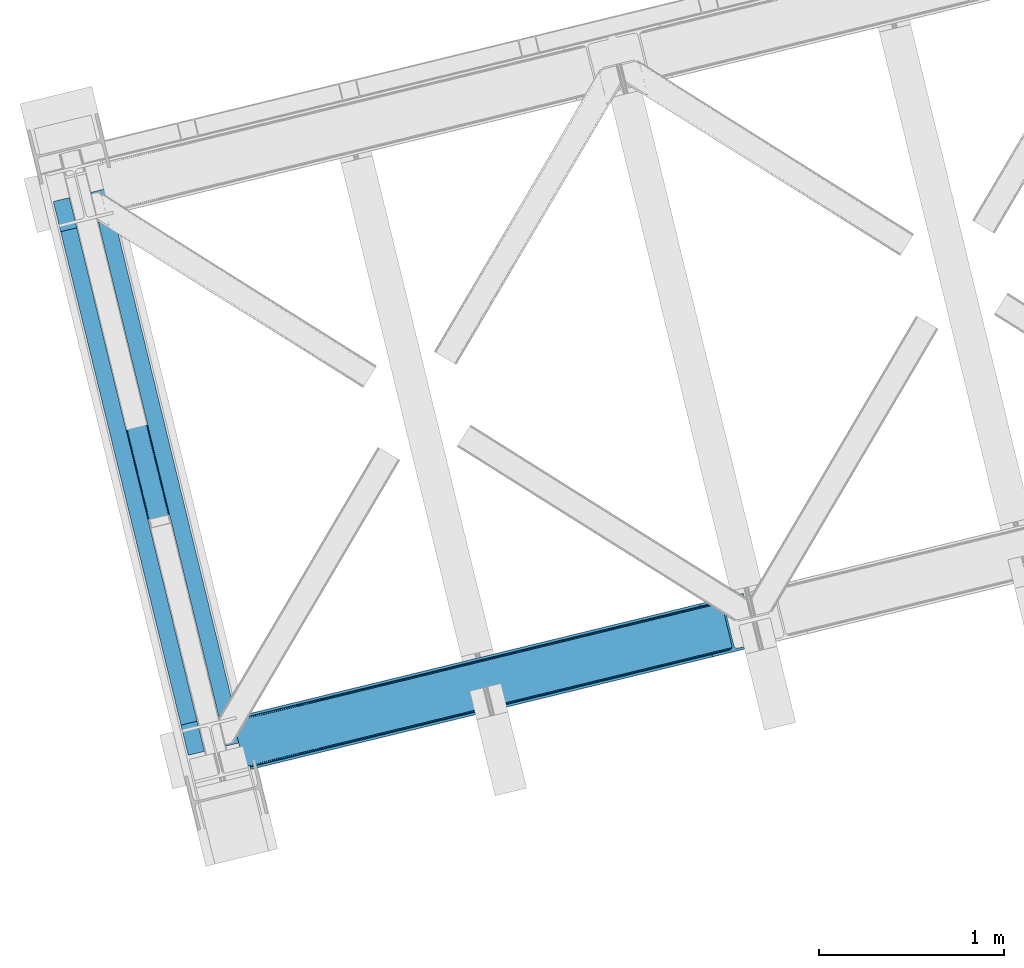
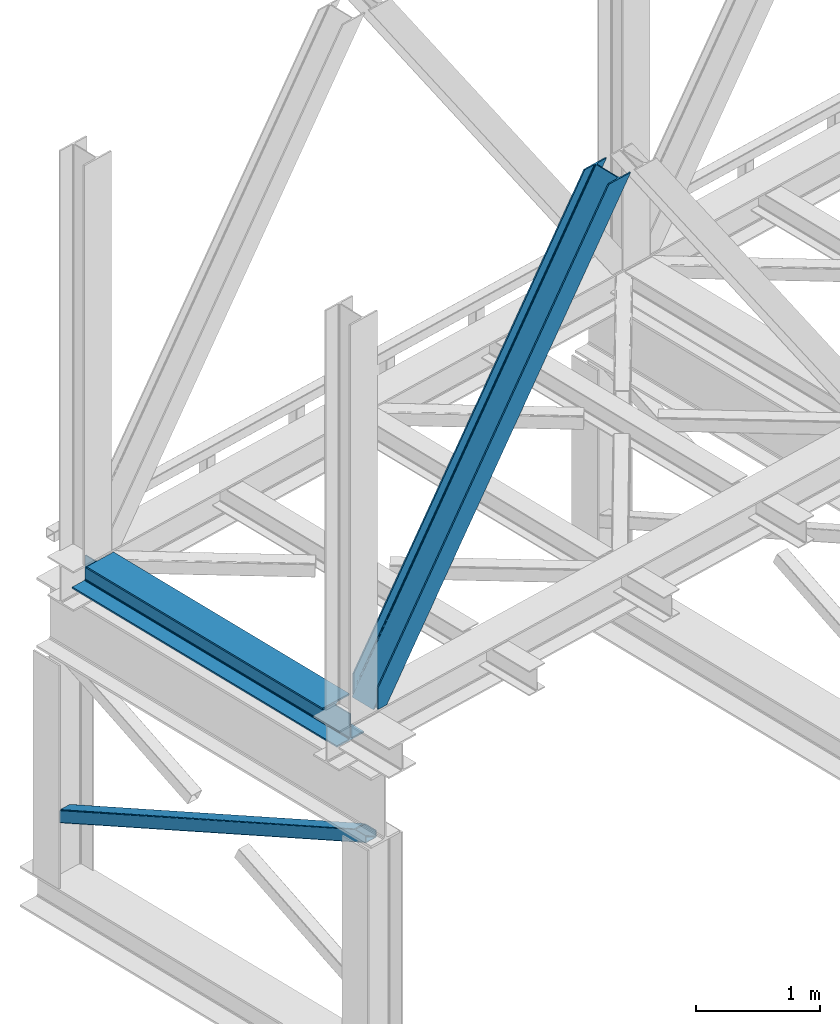
# One storey, part 24 of 92: 2 members, 1 beam.
"""IFC4 building model written with IfcOpenShell, lengths in millimetres."""

from ifc_helpers import new_model, entity, si_unit, converted_unit, derived_unit, direction, frame, origin, place, context, subcontext, project, spatial, triangles, polygons, material, type_object, element, save


model = new_model("IFC4")

# Units and contexts
model_context = context("Model", 3, precision=0.01, world=origin(), true_north=direction((6.12303176911189e-17, 1.0)))
plan_context = context("Plan", 3, precision=0.01, world=origin(), true_north=direction((6.12303176911189e-17, 1.0)))
body_context = subcontext(model_context, "Body", "Model", "MODEL_VIEW")
ifc_project = project(units=[si_unit("LENGTHUNIT", "METRE", prefix="MILLI"), si_unit("AREAUNIT", "SQUARE_METRE"), si_unit("VOLUMEUNIT", "CUBIC_METRE"), converted_unit("PLANEANGLEUNIT", "DEGREE", entity("IfcRatioMeasure", 0.0174532925199433), si_unit("PLANEANGLEUNIT", "RADIAN"), dimensions=[0, 0, 0, 0, 0, 0, 0]), si_unit("MASSUNIT", "GRAM", prefix="KILO"), derived_unit("MASSDENSITYUNIT", [(si_unit("MASSUNIT", "GRAM", prefix="KILO"), 1), (si_unit("LENGTHUNIT", "METRE"), -3)]), derived_unit("MOMENTOFINERTIAUNIT", [(si_unit("LENGTHUNIT", "METRE"), 4)]), si_unit("TIMEUNIT", "SECOND"), si_unit("FREQUENCYUNIT", "HERTZ"), si_unit("THERMODYNAMICTEMPERATUREUNIT", "DEGREE_CELSIUS"), derived_unit("THERMALTRANSMITTANCEUNIT", [(si_unit("MASSUNIT", "GRAM", prefix="KILO"), 1), (si_unit("THERMODYNAMICTEMPERATUREUNIT", "KELVIN"), -1), (si_unit("TIMEUNIT", "SECOND"), -3)]), derived_unit("VOLUMETRICFLOWRATEUNIT", [(si_unit("LENGTHUNIT", "METRE"), 3), (si_unit("TIMEUNIT", "SECOND"), -1)]), derived_unit("MASSFLOWRATEUNIT", [(si_unit("MASSUNIT", "GRAM", prefix="KILO"), 1), (si_unit("TIMEUNIT", "SECOND"), -1)]), derived_unit("ROTATIONALFREQUENCYUNIT", [(si_unit("TIMEUNIT", "SECOND"), -1)]), si_unit("ELECTRICCURRENTUNIT", "AMPERE"), si_unit("ELECTRICVOLTAGEUNIT", "VOLT"), si_unit("POWERUNIT", "WATT"), si_unit("FORCEUNIT", "NEWTON", prefix="KILO"), si_unit("ILLUMINANCEUNIT", "LUX"), si_unit("LUMINOUSFLUXUNIT", "LUMEN"), si_unit("LUMINOUSINTENSITYUNIT", "CANDELA"), derived_unit("USERDEFINED", [(si_unit("MASSUNIT", "GRAM", prefix="KILO"), -1), (si_unit("LENGTHUNIT", "METRE"), -2), (si_unit("TIMEUNIT", "SECOND"), 3), (si_unit("LUMINOUSFLUXUNIT", "LUMEN"), 1)]), derived_unit("LINEARVELOCITYUNIT", [(si_unit("LENGTHUNIT", "METRE"), 1), (si_unit("TIMEUNIT", "SECOND"), -1)]), si_unit("PRESSUREUNIT", "PASCAL"), derived_unit("USERDEFINED", [(si_unit("LENGTHUNIT", "METRE"), -2), (si_unit("MASSUNIT", "GRAM", prefix="KILO"), 1), (si_unit("TIMEUNIT", "SECOND"), -2)]), derived_unit("LINEARFORCEUNIT", [(si_unit("MASSUNIT", "GRAM", prefix="KILO"), 1), (si_unit("LENGTHUNIT", "METRE"), 1), (si_unit("TIMEUNIT", "SECOND"), -2), (si_unit("LENGTHUNIT", "METRE"), -1)]), derived_unit("PLANARFORCEUNIT", [(si_unit("MASSUNIT", "GRAM", prefix="KILO"), 1), (si_unit("LENGTHUNIT", "METRE"), 1), (si_unit("TIMEUNIT", "SECOND"), -2), (si_unit("LENGTHUNIT", "METRE"), -2)])], contexts=[model_context, plan_context])

# Site, building, storey
site_placement = place(None, origin())
site = spatial("IfcSite", under=ifc_project, at=site_placement, CompositionType="ELEMENT")
building_placement = place(site_placement, origin())
building = spatial("IfcBuilding", under=site, at=building_placement, CompositionType="ELEMENT")
storey_placement = place(building_placement, frame((0.0, 0.0, 15900.0)))
storey = spatial("IfcBuildingStorey", under=building, at=storey_placement, Name="05", CompositionType="ELEMENT", Elevation=15900.0)

# Beam
ifc_material = material(Name="Metal painted (White)")
beam_type = type_object("IfcBeamType", PredefinedType="BEAM")
beam_placement = place(storey_placement, frame((-61153.94, 2879.79, 3385.0)))
element("IfcBeam", 1, at=beam_placement, inside=storey, type_object=beam_type, material=ifc_material, ObjectType="Steel Beam", PredefinedType="BEAM", context=body_context, shape_type="Tessellation", body=[
    polygons([(1022.42935345713, 71.0478278971005, 15.4999999999986), (1022.42935345711, 71.0478278971005, 0.0), (291.465617442429, 3069.74325535076, 0.0), (291.465617442446, 3069.74325535076, 15.4999999999986), (899.042242073153, 40.970914087328, 15.4999999999986), (168.078506058474, 3039.66634154099, 15.4999999999986), (892.34989829919, 39.3395844888232, 16.8701684147963), (161.386162284511, 3038.03501194248, 16.8701684147963), (886.676403198575, 37.9566100336508, 20.7720779386413), (155.712667183895, 3036.65203748731, 20.7720779386413), (882.88549497, 37.0325360459173, 26.6116982174294), (151.92175895532, 3035.72796349958, 26.6116982174294), (881.554305026603, 36.7080444135018, 33.500000000001), (150.590569011932, 3035.40347186716, 33.500000000001), (140.875048430514, 3033.03521093726, 33.500000000001), (140.875048430514, 3033.03521093726, 259.000000000002), (150.590569011924, 3035.40347186716, 259.000000000002), (-8.66293703438714e-12, 2998.69542745366, 0.0), (-8.66293703438714e-12, 2998.69542745366, 15.4999999999986), (123.387111383964, 3028.77234126343, 15.4999999999986), (130.079455157918, 3030.40367086194, 16.8701684147963), (135.752950258542, 3031.78664531711, 20.7720779386413), (139.543858487117, 3032.71071930484, 26.6116982174294), (881.554305026594, 36.7080444135013, 259.000000000002), (871.838784445184, 34.3397834835981, 259.000000000002), (871.838784445184, 34.3397834835981, 33.500000000001), (870.507594501779, 34.0152918511832, 26.6116982174294), (866.716686273221, 33.0912178634486, 20.7720779386413), (861.043191172597, 31.7082434082767, 16.8701684147963), (854.350847398634, 30.0769138097725, 15.4999999999986), (730.963736014671, -5.41433564649196e-13, 15.4999999999986), (730.963736014671, -5.41433564649196e-13, 0.0), (841.854534586231, 199.571930111228, 259.069791776412), (190.199733064555, 2872.911390143, 259.000000000002), (190.423126166404, 2871.99494573803, 259.61730333112), (190.43551501003, 2871.94412150426, 266.500003008253), (841.709355772731, 200.167408132522, 266.500002998871), (841.709705893475, 200.165971827788, 260.000004007589), (832.229597305436, 196.831858094284, 259.006343172366), (832.006227290712, 197.74830961273, 259.61730333112), (831.993838447078, 197.799133846503, 266.500003008253), (180.719997684385, 2869.57584721824, 266.500002998871), (180.719647563625, 2869.57728352297, 260.000004007589), (180.574841905289, 2870.17133233676, 259.07612046749), (180.484212483136, 2870.5431292131, 259.000000000002), (843.040843642659, 200.490677577208, 273.388305639783), (846.831120231346, 201.417342749121, 279.227924098781), (852.504191178885, 202.802057212798, 283.129832400619), (859.196382860018, 204.434010743611, 284.500000377228), (982.583411547862, 234.511263798722, 284.500000138971), (982.58174174121, 234.518113867454, 299.999995328161), (691.11631964394, 163.469484603412, 299.999995890962), (691.1179894506, 163.46263453468, 284.500000701776), (814.505018138427, 193.539887589791, 284.500000463519), (821.197505034574, 195.17063005637, 283.129832461069), (826.871416683335, 196.551895700895, 279.227924137322), (830.662951470335, 197.473399350192, 273.388305663684), (179.38850981445, 2869.25257777355, 273.388305639783), (175.598233225754, 2868.32591260164, 279.227924098781), (169.925162278215, 2866.94119813796, 283.129832400619), (163.232970597099, 2865.30924460715, 284.500000377228), (39.8459419092461, 2835.23199155204, 284.500000138971), (39.8476117159065, 2835.2251414833, 299.999995328161), (331.313033813168, 2906.27377074735, 299.999995890962), (331.311364006516, 2906.28062081608, 284.500000701776), (207.924335318672, 2876.20336776097, 284.500000463519), (201.231848422525, 2874.57262529439, 283.129832461069), (195.557936773773, 2873.19135964986, 279.227924137322), (191.766401986782, 2872.26985600057, 273.388305663684)], [[[1, 2, 3, 4]], [[5, 1, 4, 6]], [[7, 5, 6, 8]], [[9, 7, 8, 10]], [[11, 9, 10, 12]], [[13, 11, 12, 14]], [[15, 16, 17, 14, 12, 10, 8, 6, 4, 3, 18, 19, 20, 21, 22, 23]], [[13, 24, 25, 26, 27, 28, 29, 30, 31, 32, 2, 1, 5, 7, 9, 11]], [[2, 32, 18, 3]], [[32, 31, 19, 18]], [[31, 30, 20, 19]], [[27, 26, 15, 23]], [[28, 27, 23, 22]], [[29, 28, 22, 21]], [[30, 29, 21, 20]], [[33, 24, 13, 14, 17, 34, 35, 36, 37, 38]], [[25, 39, 40, 41, 42, 43, 44, 16, 15, 26]], [[39, 25, 24, 33]], [[45, 34, 17, 16]], [[41, 40, 38, 37, 46, 47, 48, 49, 50, 51, 52, 53, 54, 55, 56, 57]], [[42, 58, 59, 60, 61, 62, 63, 64, 65, 66, 67, 68, 69, 36, 35, 43]], [[46, 37, 36, 69]], [[47, 46, 69, 68]], [[48, 47, 68, 67]], [[49, 48, 67, 66]], [[50, 49, 66, 65]], [[51, 50, 65, 64]], [[52, 51, 64, 63]], [[53, 52, 63, 62]], [[54, 53, 62, 61]], [[55, 54, 61, 60]], [[56, 55, 60, 59]], [[57, 56, 59, 58]], [[41, 57, 58, 42]]], closed=False),
])

# Members
member_type_1 = type_object("IfcMemberType", PredefinedType="BRACE")
member_1_placement = place(storey_placement, frame((-60179.56, 2803.34, 3685.0)))
element("IfcMember", 2, at=member_1_placement, inside=storey, type_object=member_type_1, ObjectType="Steel Vertical Brace", PredefinedType="BRACE", context=body_context, shape_type="Tessellation", body=[
    triangles([(58.5731689453096, 23.1982933044433, 0.0), (60.4660766601592, 15.4260932922361, 0.0), (59.1080200195283, 16.2394157409667, 0.781347656247817), (58.9684936523408, 15.0609992980958, 1.0697021484375), (78.1673217773423, 19.740655517578, 8.06229858398365), (78.1673217773423, 19.740655517578, 29.5563354492188), (72.7350952148408, 18.4163177490232, 0.0), (500.42061767578, 117.802693176269, 660.427130126951), (82.4554321289033, 19.9240745544435, 36.4024291992173), (86.4877441406279, 18.4526527404782, 44.3670593261704), (502.150744628903, 124.235730743408, 658.201684570311), (88.0643920898438, 17.2873168945312, 48.5435485839844), (2700.97932128907, 660.223363494873, 3921.00020141601), (2700.97001953125, 667.310721588135, 3921.00020141601), (2273.78214111328, 563.179286956787, 3287.10633544922), (2274.3169921875, 556.220118713379, 3287.88535766601), (2697.74696044922, 653.425231933594, 3921.00020141601), (2272.58686523438, 549.787371826172, 3290.11080322265), (2691.77058105469, 647.951147460938, 3921.00020141601), (2268.84755859375, 544.860056304932, 3293.43850708008), (2683.94780273438, 644.634780120849, 3921.00020141601), (2263.67578125, 542.188417053223, 3297.36384887695), (491.5048828125, 110.204029083252, 667.68017578125), (496.681311035158, 112.875377655029, 663.754833984374), (91.1758300781221, 12.6192878723145, 73.6396911621086), (90.6456298828125, 13.9003143310547, 61.2474243164033), (89.48291015625, 15.426383972168, 55.5245178222649), (501.611242675783, 131.194608306885, 657.42033691406), (945.193469238278, 232.231755065918, 1315.62202148437), (944.653967285158, 239.190632629394, 1314.84299926758), (1388.23619384765, 340.227779388428, 1973.04468383789), (1387.69669189453, 347.186947631836, 1972.26333618164), (1831.27426757813, 448.224094390869, 2630.46502075195), (1830.73941650391, 455.182971954346, 2629.6836730957), (943.458691406253, 225.799008178711, 1317.84746704101), (1386.50141601563, 333.795032501221, 1975.26780395508), (1829.544140625, 441.791347503662, 2632.68814086914), (939.724035644533, 220.871692657471, 1321.17517089844), (1382.76676025391, 328.86771697998, 1978.5955078125), (1825.80483398437, 436.864031982422, 2636.01817016601), (934.547607421875, 218.200053405762, 1325.10051269531), (1377.59033203125, 326.196077728272, 1982.52317504883), (1820.63305664063, 434.192392730713, 2639.94351196289), (91.1758300781221, 12.6192878723145, 210.054620361327), (2592.01853027344, 622.225392150879, 3921.00020141601), (1332.51866455078, 573.558595275879, 1972.26333618164), (2645.7873413086, 893.682369232178, 3921.00020141601), (2218.59946289063, 789.55093460083, 3287.10633544922), (1775.55673828125, 681.554619598388, 2629.6836730957), (889.475939941403, 465.562280273437, 1314.84299926758), (446.433215332028, 357.566255950928, 657.42033691406), (3.39049072265334, 249.569940948486, 0.0), (86.4877441406279, 18.4526527404782, 15.6757873535134), (82.4554321289033, 19.9240745544435, 13.352673339843), (84.3529907226548, 19.4549171447752, 14.892114257811), (88.0643920898438, 17.2873168945312, 15.1293090820291), (91.4595336914063, 11.6585906982423, 0.0), (90.6456298828125, 13.9003143310547, 7.3414123535149), (89.6456909179688, 15.5502136230466, 12.4201721191384), (91.4595336914063, 11.6585906982423, 210.119732666015), (91.1153686523467, 12.7907890319825, 0.0), (2595.09741210938, 609.595349121093, 3921.00020141601), (94.3012207031279, 0.0, 210.119732666015), (94.3012207031279, 0.0, 0.0), (189.179150390628, 23.1273674011231, 0.0), (2831.57600097657, 667.239795684814, 3921.00020141601), (94.1663452148423, 13.3483131408689, 0.0), (186.100268554685, 35.7577011108397, 0.0), (2828.49711914063, 679.8698387146, 3921.00020141601), (1411.90916748047, 334.561846160889, 1955.37134399414), (2305.60810546875, 552.410758209228, 3281.5159790039), (1858.76096191406, 443.486302185058, 2618.4424987793), (2736.56319580078, 657.460741424561, 3921.00020141601), (965.057373046875, 225.637390136719, 1292.29786376953), (518.210229492186, 116.712934112549, 629.226708984374), (512.387329101563, 116.703632354736, 633.152050781249), (72.1351318359375, 19.4709045410154, 0.0), (502.299572753909, 124.272356414795, 638.705200195313), (506.796972656251, 119.358121490478, 636.479754638669), (499.574157714844, 130.698126983642, 639.484222412109), (2728.0939453125, 656.806420898437, 3921.00020141601), (2299.78520507813, 552.401747131348, 3285.44132080078), (2720.26651611328, 658.914141082764, 3921.00020141601), (2294.19949951172, 555.05623626709, 3288.7690246582), (2714.27153320313, 663.462991333008, 3921.00020141601), (2289.70209960938, 559.970471191406, 3290.99447021484), (2711.02056884766, 669.760572052002, 3921.00020141601), (2286.97668457031, 566.395951080322, 3291.77349243164), (68.6237182617188, 25.6484344482419, 0.0), (959.234472656251, 225.628088378906, 1296.22320556641), (1406.08626708984, 334.552544403076, 1959.29668579101), (1852.93806152344, 443.477000427246, 2622.37016601562), (953.648767089842, 228.282577514648, 1299.55323486328), (1400.50056152344, 337.207033538818, 1962.62438964844), (1847.35235595703, 446.131489562988, 2625.69786987305), (949.1513671875, 233.196812438965, 1301.77635498047), (1396.00316162109, 342.121268463135, 1964.84983520508), (1842.85030517578, 451.046015167236, 2627.92098999023), (946.425952148435, 239.622583007812, 1302.55770263672), (1393.27774658203, 348.547039031982, 1965.62885742187), (1840.12954101562, 457.471495056152, 2628.70233764648), (1784.94686279297, 683.843142700195, 2628.70233764648), (1338.09506835938, 574.918686676025, 1965.62885742187), (2655.837890625, 896.132219696045, 3921.00020141601), (2231.79865722657, 792.767598724365, 3291.77349243164), (891.247924804688, 465.994230651856, 1302.55770263672), (444.396130371097, 357.069774627686, 639.484222412109), (13.4410400390625, 252.020082092285, 0.0), (1.49758300781104, 257.342431640625, 0.0), (13.7154418945283, 259.120811462402, 0.0), (13.7619506835908, 260.332946777344, 0.0), (0.665075683595205, 255.995711517334, 0.781347656247817), (0.0, 256.977628326416, 1.0697021484375), (19.1988281250015, 261.656993865967, 8.06229858398365), (19.1988281250015, 261.656993865967, 29.5563354492188), (439.210400390628, 368.906261444092, 660.427130126951), (433.624694824219, 371.560750579834, 663.754833984374), (27.5890136718735, 272.585396575927, 61.2474243164033), (27.4634399414063, 270.661095428467, 54.4989990234353), (443.70780029297, 363.992026519775, 658.201684570311), (23.0869628906221, 263.467639160156, 36.4024291992173), (26.5565185546875, 268.18304901123, 48.2714721679658), (25.9891113281265, 266.629364776611, 44.3670593261704), (427.801794433595, 371.551448822021, 667.68017578125), (27.4727416992173, 273.966998291015, 73.6396911621086), (2628.70931396484, 906.63622970581, 3921.00020141601), (2620.24006347657, 905.982199859619, 3921.00020141601), (2205.79094238282, 803.545138549805, 3293.43850708008), (2199.96804199219, 803.536127471924, 3297.36384887695), (2636.54139404297, 904.528509521484, 3921.00020141601), (2211.37664794922, 800.890649414062, 3290.11080322265), (2642.53637695313, 899.97965927124, 3921.00020141601), (2215.87404785156, 795.976414489746, 3287.88535766601), (876.667419433594, 479.556774902343, 1321.17517089844), (870.84451904297, 479.547473144531, 1325.10051269531), (1319.70549316406, 587.552799224854, 1978.5955078125), (1313.88259277344, 587.543788146972, 1982.52317504883), (1762.74821777344, 695.549114227295, 2636.01817016601), (1756.92531738281, 695.539812469483, 2639.94351196289), (882.253125000003, 476.902285766601, 1317.84746704101), (1325.29584960938, 584.898310089111, 1975.26780395508), (1768.33392333984, 692.894625091553, 2632.68814086914), (886.750524902345, 471.988050842285, 1315.62202148437), (1329.79324951172, 579.984365844727, 1973.04468383789), (1772.83132324219, 687.980390167236, 2630.46502075195), (2528.31079101563, 883.57310256958, 3921.00020141601), (27.4727416992173, 273.966998291015, 210.054620361327), (449.326062011722, 375.388714599609, 633.152050781249), (445.591406250001, 370.461399078369, 636.479754638669), (26.8541748046846, 268.390594482422, 15.1293090820291), (27.4634399414063, 270.661095428467, 12.4201721191384), (454.502490234372, 378.060353851318, 629.226708984374), (27.5890136718735, 272.585396575927, 7.3414123535149), (30.4632568359375, 274.695732879638, 0.0), (443.856628417969, 364.028652191162, 638.705200195313), (25.9891113281265, 266.629364776611, 15.6757873535134), (23.0869628906221, 263.467639160156, 13.352673339843), (24.5612915039092, 264.760583496094, 14.8944396972656), (2655.82858886719, 903.219577789307, 3921.00020141601), (2231.25915527344, 799.726766967774, 3290.99447021484), (2659.05629882812, 910.017418670654, 3921.00020141601), (2232.99393310547, 806.159513854981, 3288.7690246582), (2665.03732910156, 915.491503143311, 3921.00020141601), (2236.72858886719, 811.086829376221, 3285.44132080078), (2672.86010742188, 918.80816116333, 3921.00020141601), (2241.90501708985, 813.75846862793, 3281.5159790039), (27.4959960937485, 273.78706741333, 0.0), (890.70842285156, 472.953108215332, 1301.77635498047), (1337.56021728516, 581.877564239502, 1964.84983520508), (1784.40736083985, 690.802310943604, 2627.92098999023), (892.43854980469, 479.385855102539, 1299.55323486328), (1339.29034423828, 588.310601806641, 1962.62438964844), (1786.14213867188, 697.235057830811, 2625.69786987305), (896.177856445313, 484.313170623779, 1296.22320556641), (1343.0296508789, 593.237626647949, 1959.29668579101), (1789.8814453125, 702.162082672119, 2622.37016601562), (901.35428466797, 486.984809875488, 1292.29786376953), (1348.20142822266, 595.909265899658, 1955.37134399414), (1795.05322265625, 704.83401260376, 2618.4424987793), (27.2774047851563, 274.949205780029, 0.0), (27.2774047851563, 274.949205780029, 210.119732666015), (2525.23190917969, 896.203145599365, 3921.00020141601), (24.4357177734346, 286.607796478271, 210.119732666015), (24.4357177734346, 286.607796478271, 0.0), (2761.71049804688, 953.847592163086, 3921.00020141601), (2764.78937988282, 941.217258453369, 3921.00020141601), (119.313647460935, 309.735454559326, 0.0), (122.392529296878, 297.105120849609, 0.0)], [[1, 2, 3], [4, 3, 2], [5, 4, 2], [4, 5, 6], [2, 7, 5], [8, 9, 10], [11, 3, 6], [6, 8, 11], [6, 9, 8], [3, 4, 6], [10, 12, 8], [13, 14, 15], [15, 16, 13], [17, 13, 16], [16, 18, 17], [19, 17, 18], [18, 20, 19], [21, 19, 20], [20, 22, 21], [23, 24, 25], [26, 25, 24], [26, 8, 27], [26, 24, 8], [12, 27, 8], [11, 28, 3], [1, 3, 28], [29, 30, 28], [28, 11, 29], [31, 32, 30], [30, 29, 31], [33, 34, 32], [32, 31, 33], [16, 15, 34], [34, 33, 16], [35, 29, 11], [11, 8, 35], [36, 31, 29], [29, 35, 36], [37, 33, 31], [31, 36, 37], [18, 16, 33], [33, 37, 18], [38, 35, 24], [8, 24, 35], [39, 36, 38], [35, 38, 36], [40, 37, 39], [36, 39, 37], [20, 18, 40], [37, 40, 18], [41, 38, 24], [24, 23, 41], [42, 39, 38], [38, 41, 42], [43, 40, 39], [39, 42, 43], [22, 20, 40], [40, 43, 22], [42, 44, 45], [45, 22, 43], [22, 45, 21], [43, 42, 45], [44, 42, 41], [41, 23, 44], [25, 44, 23], [34, 46, 32], [14, 47, 48], [49, 15, 48], [46, 34, 49], [48, 15, 14], [49, 34, 15], [32, 50, 30], [50, 51, 28], [50, 32, 46], [52, 1, 51], [50, 28, 30], [51, 1, 28], [53, 10, 9], [9, 54, 55], [56, 27, 12], [56, 12, 10], [10, 53, 56], [57, 26, 58], [58, 26, 27], [27, 59, 58], [57, 60, 25], [44, 25, 60], [25, 26, 57], [58, 61, 57], [56, 59, 27], [9, 55, 53], [54, 9, 6], [6, 5, 54], [62, 60, 63], [62, 45, 60], [44, 60, 45], [64, 63, 60], [60, 57, 64], [62, 65, 66], [65, 62, 63], [64, 65, 63], [65, 67, 64], [67, 65, 68], [61, 57, 67], [57, 64, 67], [69, 66, 68], [65, 68, 66], [70, 69, 68], [71, 69, 72], [71, 73, 69], [70, 72, 69], [68, 74, 70], [75, 74, 68], [68, 67, 75], [76, 59, 56], [76, 58, 59], [77, 78, 5], [78, 55, 54], [78, 53, 55], [54, 5, 78], [5, 7, 77], [78, 79, 56], [56, 53, 78], [80, 78, 77], [67, 61, 58], [76, 75, 58], [67, 58, 75], [81, 73, 71], [71, 82, 81], [83, 81, 82], [82, 84, 83], [85, 83, 84], [84, 86, 85], [87, 85, 86], [86, 88, 87], [77, 89, 80], [56, 79, 76], [90, 74, 75], [75, 76, 90], [91, 70, 90], [74, 90, 70], [92, 72, 91], [70, 91, 72], [82, 71, 92], [72, 92, 71], [93, 90, 76], [76, 79, 93], [94, 91, 90], [90, 93, 94], [95, 92, 91], [91, 94, 95], [84, 82, 92], [92, 95, 84], [96, 93, 78], [79, 78, 93], [97, 94, 93], [93, 96, 97], [98, 95, 94], [94, 97, 98], [86, 84, 95], [95, 98, 86], [99, 96, 80], [78, 80, 96], [100, 97, 99], [96, 99, 97], [101, 98, 100], [97, 100, 98], [88, 86, 101], [98, 101, 86], [102, 100, 103], [104, 87, 88], [101, 105, 88], [100, 102, 101], [88, 105, 104], [101, 102, 105], [103, 99, 106], [99, 80, 107], [99, 103, 100], [89, 108, 80], [99, 107, 106], [80, 108, 107], [109, 108, 110], [1, 89, 108], [1, 108, 52], [1, 2, 89], [109, 52, 108], [7, 77, 2], [77, 89, 2], [110, 111, 109], [109, 52, 112], [112, 113, 109], [113, 114, 109], [113, 115, 114], [111, 109, 114], [116, 117, 118], [118, 119, 116], [120, 121, 115], [115, 112, 120], [115, 113, 112], [120, 116, 122], [122, 123, 120], [123, 121, 120], [119, 122, 116], [117, 124, 125], [125, 118, 117], [126, 127, 128], [129, 128, 127], [130, 126, 131], [128, 131, 126], [132, 130, 133], [131, 133, 130], [47, 132, 48], [133, 48, 132], [134, 135, 124], [124, 117, 134], [136, 137, 134], [135, 134, 137], [138, 139, 136], [137, 136, 139], [128, 129, 138], [139, 138, 129], [140, 134, 117], [117, 116, 140], [141, 136, 134], [134, 140, 141], [142, 138, 136], [136, 141, 142], [131, 128, 138], [138, 142, 131], [143, 140, 120], [116, 120, 140], [144, 141, 143], [140, 143, 141], [145, 142, 144], [141, 144, 142], [133, 131, 145], [142, 145, 131], [51, 120, 112], [112, 52, 51], [50, 143, 51], [120, 51, 143], [46, 144, 50], [143, 50, 144], [49, 145, 46], [144, 46, 145], [48, 133, 49], [145, 49, 133], [146, 147, 137], [137, 139, 146], [139, 129, 146], [127, 146, 129], [135, 137, 147], [147, 125, 124], [124, 135, 147], [148, 149, 150], [150, 151, 148], [152, 148, 153], [153, 154, 152], [107, 108, 110], [155, 156, 150], [155, 110, 114], [114, 157, 155], [157, 158, 155], [158, 156, 155], [110, 111, 114], [150, 149, 155], [110, 155, 107], [159, 104, 160], [105, 160, 104], [161, 159, 162], [160, 162, 159], [163, 161, 164], [162, 164, 161], [165, 163, 166], [164, 166, 163], [153, 167, 154], [151, 153, 148], [168, 106, 107], [107, 155, 168], [169, 103, 106], [106, 168, 169], [170, 102, 103], [103, 169, 170], [160, 105, 102], [102, 170, 160], [171, 168, 155], [155, 149, 171], [172, 169, 171], [168, 171, 169], [173, 170, 172], [169, 172, 170], [162, 160, 173], [170, 173, 160], [174, 171, 148], [149, 148, 171], [175, 172, 174], [171, 174, 172], [176, 173, 175], [172, 175, 173], [164, 162, 176], [173, 176, 162], [177, 174, 152], [148, 152, 174], [178, 175, 174], [174, 177, 178], [179, 176, 175], [175, 178, 179], [166, 164, 176], [176, 179, 166], [156, 158, 121], [121, 123, 156], [150, 156, 123], [123, 122, 150], [119, 151, 150], [118, 153, 119], [151, 119, 153], [180, 167, 153], [153, 125, 180], [181, 180, 125], [125, 147, 181], [118, 125, 153], [122, 119, 150], [158, 157, 121], [121, 157, 115], [114, 115, 157], [182, 181, 146], [181, 182, 183], [181, 147, 146], [180, 181, 184], [183, 184, 181], [47, 14, 104], [17, 19, 81], [21, 62, 66], [45, 62, 21], [19, 21, 73], [14, 13, 85], [13, 17, 83], [130, 163, 126], [182, 127, 185], [127, 126, 165], [182, 146, 127], [130, 132, 161], [132, 47, 159], [104, 14, 87], [73, 81, 19], [85, 13, 83], [81, 83, 17], [85, 87, 14], [66, 73, 21], [66, 69, 73], [165, 126, 163], [161, 132, 159], [104, 159, 47], [161, 163, 130], [165, 185, 127], [185, 165, 186], [187, 154, 184], [154, 187, 188], [167, 180, 154], [180, 184, 154], [182, 187, 183], [182, 185, 187], [187, 184, 183], [186, 178, 188], [179, 186, 166], [186, 179, 178], [186, 165, 166], [177, 188, 178], [154, 188, 152], [177, 152, 188], [185, 186, 188], [188, 187, 185]]),
])
member_type_2 = type_object("IfcMemberType", PredefinedType="BRACE")
member_2_placement = place(storey_placement, frame((-61123.58, 2666.96, 911.28)))
element("IfcMember", 3, at=member_2_placement, inside=storey, type_object=member_type_2, ObjectType="Steel Vertical Brace", PredefinedType="BRACE", context=body_context, shape_type="Tessellation", body=[
    triangles([(109.78864746094, 3493.74459457398, 0.0), (954.899853515628, 26.7614479064941, 1610.78191223144), (6.80423583984521, 3468.64147567749, 0.0), (851.915441894533, 1.65774765014658, 1610.78191223144), (112.19315185547, 3494.33118667603, 1.12551269531104), (957.304357910158, 27.3474586486818, 1611.90626220703), (114.59765625, 3494.91719741821, 2.24986267089844), (959.708862304688, 27.9334693908695, 1613.03061218261), (115.592944335935, 3495.1596244812, 4.96481323242188), (960.704150390622, 28.1761871337894, 1615.74672546387), (116.588232421876, 3495.40263290405, 7.68092651366896), (961.704089355466, 28.4191955566407, 1618.46167602539), (0.99993896484375, 3467.22644577026, 4.96481323242188), (846.111145019531, 0.242717742919922, 1615.74672546387), (0.0, 3466.98343734741, 7.68092651366896), (845.115856933597, 0.0, 1618.46167602539), (1.99522705077834, 3467.46887283325, 2.24986267089844), (847.106433105466, 0.485435485839844, 1613.03061218261), (4.39973144531541, 3468.05488357544, 1.12551269531104), (849.510937500003, 1.07173690795935, 1611.90626220703), (933.347680664061, 144.732444763184, 1680.7206665039), (116.588232421876, 3495.40263290405, 123.979641723632), (961.704089355466, 28.4191955566407, 1680.7206665039), (816.764099121094, 116.313249206543, 1680.7206665039), (0.0, 3466.98343734741, 123.979641723632), (845.115856933597, 0.0, 1680.7206665039), (112.19315185547, 3494.33118667603, 130.53505554199), (109.78864746094, 3493.74459457398, 131.659405517577), (922.52043457031, 159.605083465576, 1680.7206665039), (114.59765625, 3494.91719741821, 129.409542846679), (925.427233886716, 158.981284332276, 1680.7206665039), (115.592944335935, 3495.1596244812, 126.694592285156), (928.506115722659, 155.935540008545, 1680.7206665039), (931.287341308591, 150.932066345215, 1680.7206665039), (6.80423583984521, 3468.64147567749, 131.659405517577), (819.536022949222, 134.501383209229, 1680.7206665039), (815.740905761719, 122.76547164917, 1680.7206665039), (0.99993896484375, 3467.22644577026, 126.694592285156), (815.903686523438, 128.487796783447, 1680.7206665039), (1.99522705077834, 3467.46887283325, 129.409542846679), (817.23848876953, 132.608766174317, 1680.7206665039), (4.39973144531541, 3468.05488357544, 130.53505554199), (923.45061035156, 145.989635467529, 1680.7206665039), (926.529492187503, 142.944181823731, 1680.7206665039), (920.539160156251, 146.61343460083, 1680.7206665039), (931.371057128905, 131.74108657837, 1680.7206665039), (956.843920898435, 27.234965515137, 1680.7206665039), (929.310717773435, 137.9407081604, 1680.7206665039), (823.642749023435, 117.864317321777, 1680.7206665039), (824.972900390625, 121.985577392578, 1680.7206665039), (827.27043457031, 123.878194427491, 1680.7206665039), (824.498510742189, 105.690060424805, 1680.7206665039), (823.475317382814, 112.142282867432, 1680.7206665039), (849.971374511719, 1.18423004150418, 1680.7206665039), (111.728063964845, 3494.21840286255, 118.492767333984), (110.732775878903, 3493.97597579956, 121.208880615231), (109.737487792969, 3493.73296737671, 123.923831176755), (107.332983398439, 3493.14695663452, 125.048181152342), (104.928479003909, 3492.56094589233, 126.173693847653), (11.6597534179673, 3469.82512435913, 126.173693847653), (9.2552490234375, 3469.23911361694, 125.048181152342), (6.85074462890771, 3468.65310287476, 123.923831176755), (5.85545654296584, 3468.4100944519, 121.208880615231), (4.86016845703125, 3468.16766738892, 118.492767333984), (111.728063964845, 3494.21840286255, 13.166638183593), (956.843920898435, 27.234965515137, 1623.94738769531), (4.86016845703125, 3468.16766738892, 13.166638183593), (849.971374511719, 1.18423004150418, 1623.94738769531), (109.737487792969, 3493.73296737671, 7.73557434081886), (107.332983398439, 3493.14695663452, 6.61122436523146), (110.732775878903, 3493.97597579956, 10.4505249023423), (104.928479003909, 3492.56094589233, 5.48571166992042), (6.85074462890771, 3468.65310287476, 7.73557434081886), (5.85545654296584, 3468.4100944519, 10.4505249023423), (9.2552490234375, 3469.23911361694, 6.61122436523146), (11.6597534179673, 3469.82512435913, 5.48571166992042), (950.044335937499, 25.5772178649904, 1616.26762390137), (952.448840332028, 26.1632286071781, 1617.39197387695), (954.853344726565, 26.7495300292971, 1618.51748657227), (856.775610351564, 2.84197769165075, 1616.26762390137), (854.371105957034, 2.25567626953125, 1617.39197387695), (851.966601562497, 1.66966552734402, 1618.51748657227), (955.8486328125, 26.9922477722171, 1621.23243713379), (850.971313476563, 1.4269477844241, 1621.23243713379)], [[1, 2, 3], [4, 3, 2], [5, 6, 2], [2, 1, 5], [7, 8, 6], [6, 5, 7], [9, 10, 8], [8, 7, 9], [11, 12, 10], [10, 9, 11], [13, 14, 15], [16, 15, 14], [17, 18, 13], [14, 13, 18], [19, 20, 17], [18, 17, 20], [3, 4, 19], [20, 19, 4], [11, 21, 12], [21, 11, 22], [23, 12, 21], [24, 15, 16], [24, 25, 15], [16, 26, 24], [27, 28, 29], [30, 27, 31], [32, 30, 33], [22, 32, 34], [34, 21, 22], [33, 34, 32], [31, 33, 30], [29, 31, 27], [29, 28, 35], [35, 36, 29], [25, 24, 37], [38, 37, 39], [40, 39, 41], [42, 41, 36], [36, 35, 42], [41, 42, 40], [39, 40, 38], [37, 38, 25], [43, 44, 34], [33, 43, 34], [29, 33, 31], [45, 29, 36], [33, 45, 43], [29, 45, 33], [44, 21, 34], [23, 46, 47], [23, 21, 46], [44, 48, 21], [48, 46, 21], [37, 49, 50], [36, 51, 45], [51, 39, 50], [39, 51, 36], [50, 39, 37], [39, 36, 41], [24, 49, 37], [52, 53, 24], [53, 49, 24], [52, 26, 54], [24, 26, 52], [55, 46, 48], [56, 48, 44], [57, 44, 43], [58, 43, 45], [45, 59, 58], [43, 58, 57], [44, 57, 56], [48, 56, 55], [59, 45, 51], [51, 60, 59], [61, 60, 51], [62, 61, 50], [63, 62, 49], [64, 63, 53], [53, 52, 64], [49, 53, 63], [50, 49, 62], [51, 50, 61], [46, 65, 66], [46, 55, 65], [66, 47, 46], [67, 52, 68], [52, 67, 64], [54, 68, 52], [58, 59, 28], [32, 57, 27], [32, 27, 30], [28, 59, 35], [28, 27, 58], [57, 58, 27], [55, 22, 11], [22, 56, 57], [55, 56, 22], [22, 57, 32], [42, 62, 38], [60, 35, 59], [61, 42, 35], [61, 35, 60], [38, 40, 42], [62, 25, 38], [42, 61, 62], [62, 63, 25], [25, 64, 15], [64, 25, 63], [69, 5, 70], [11, 65, 55], [71, 11, 69], [11, 71, 65], [69, 11, 9], [70, 1, 72], [69, 9, 5], [5, 9, 7], [72, 1, 3], [5, 1, 70], [73, 13, 15], [74, 73, 15], [75, 19, 73], [67, 15, 64], [15, 67, 74], [19, 13, 73], [3, 76, 72], [19, 75, 3], [76, 3, 75], [17, 13, 19], [77, 4, 2], [2, 6, 78], [6, 8, 10], [6, 79, 78], [2, 78, 77], [79, 6, 10], [80, 4, 77], [18, 20, 14], [20, 4, 81], [81, 82, 20], [20, 82, 14], [80, 81, 4], [14, 82, 16], [83, 12, 66], [10, 12, 79], [83, 79, 12], [23, 66, 12], [23, 47, 66], [16, 84, 68], [84, 16, 82], [68, 26, 16], [26, 68, 54], [77, 72, 76], [76, 80, 77], [66, 65, 83], [71, 83, 65], [83, 71, 79], [69, 79, 71], [79, 69, 78], [70, 78, 69], [78, 70, 77], [72, 77, 70], [80, 76, 75], [75, 81, 80], [81, 75, 73], [73, 82, 81], [82, 73, 74], [74, 84, 82], [84, 74, 67], [67, 68, 84]]),
])

save(model, "model.ifc")
